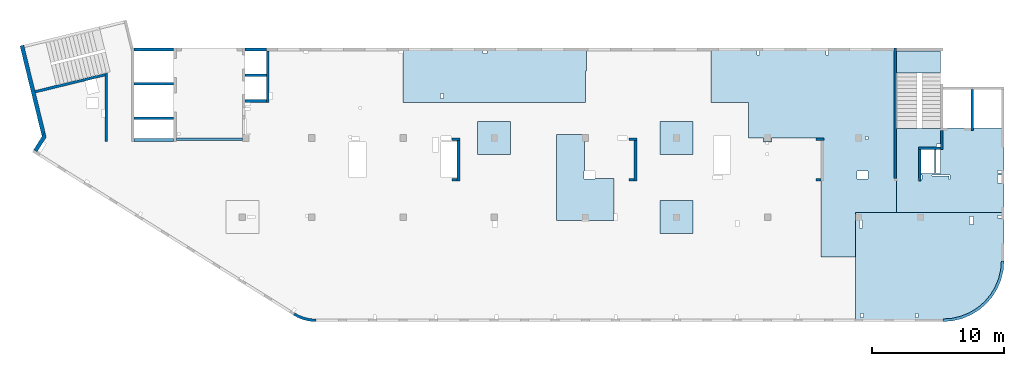
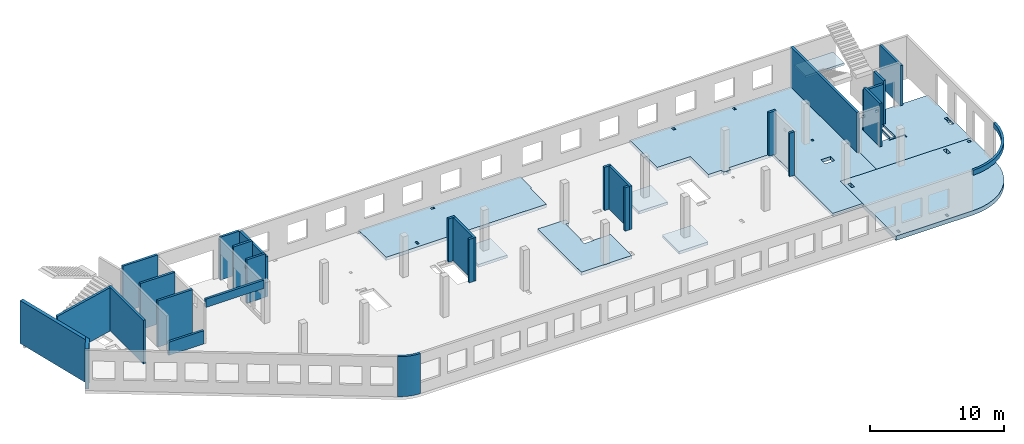
# One storey, part 2 of 6: 28 walls, 9 slabs.
"""IFC4 building model written with IfcOpenShell, lengths in millimetres."""

from ifc_helpers import new_model, entity, si_unit, converted_unit, derived_unit, direction, frame, origin, place, context, subcontext, project, spatial, indexed_curve, outline, extrude, material, type_object, element, save


model = new_model("IFC4")

# Units and contexts
model_context = context("Model", 3, precision=0.01, world=origin(), true_north=direction((6.12303176911189e-17, 1.0)))
plan_context = context("Plan", 3, precision=0.01, world=origin(), true_north=direction((6.12303176911189e-17, 1.0)))
body_context = subcontext(model_context, "Body", "Model", "MODEL_VIEW")
ifc_project = project(units=[si_unit("LENGTHUNIT", "METRE", prefix="MILLI"), si_unit("AREAUNIT", "SQUARE_METRE"), si_unit("VOLUMEUNIT", "CUBIC_METRE"), converted_unit("PLANEANGLEUNIT", "DEGREE", entity("IfcRatioMeasure", 0.0174532925199433), si_unit("PLANEANGLEUNIT", "RADIAN"), dimensions=[0, 0, 0, 0, 0, 0, 0]), si_unit("MASSUNIT", "GRAM", prefix="KILO"), derived_unit("MASSDENSITYUNIT", [(si_unit("MASSUNIT", "GRAM", prefix="KILO"), 1), (si_unit("LENGTHUNIT", "METRE"), -3)]), derived_unit("MOMENTOFINERTIAUNIT", [(si_unit("LENGTHUNIT", "METRE"), 4)]), si_unit("TIMEUNIT", "SECOND"), si_unit("FREQUENCYUNIT", "HERTZ"), si_unit("THERMODYNAMICTEMPERATUREUNIT", "DEGREE_CELSIUS"), derived_unit("THERMALTRANSMITTANCEUNIT", [(si_unit("MASSUNIT", "GRAM", prefix="KILO"), 1), (si_unit("THERMODYNAMICTEMPERATUREUNIT", "KELVIN"), -1), (si_unit("TIMEUNIT", "SECOND"), -3)]), derived_unit("VOLUMETRICFLOWRATEUNIT", [(si_unit("LENGTHUNIT", "METRE"), 3), (si_unit("TIMEUNIT", "SECOND"), -1)]), derived_unit("MASSFLOWRATEUNIT", [(si_unit("MASSUNIT", "GRAM", prefix="KILO"), 1), (si_unit("TIMEUNIT", "SECOND"), -1)]), derived_unit("ROTATIONALFREQUENCYUNIT", [(si_unit("TIMEUNIT", "SECOND"), -1)]), si_unit("ELECTRICCURRENTUNIT", "AMPERE"), si_unit("ELECTRICVOLTAGEUNIT", "VOLT"), si_unit("POWERUNIT", "WATT"), si_unit("FORCEUNIT", "NEWTON", prefix="KILO"), si_unit("ILLUMINANCEUNIT", "LUX"), si_unit("LUMINOUSFLUXUNIT", "LUMEN"), si_unit("LUMINOUSINTENSITYUNIT", "CANDELA"), derived_unit("USERDEFINED", [(si_unit("MASSUNIT", "GRAM", prefix="KILO"), -1), (si_unit("LENGTHUNIT", "METRE"), -2), (si_unit("TIMEUNIT", "SECOND"), 3), (si_unit("LUMINOUSFLUXUNIT", "LUMEN"), 1)]), derived_unit("LINEARVELOCITYUNIT", [(si_unit("LENGTHUNIT", "METRE"), 1), (si_unit("TIMEUNIT", "SECOND"), -1)]), si_unit("PRESSUREUNIT", "PASCAL"), derived_unit("USERDEFINED", [(si_unit("LENGTHUNIT", "METRE"), -2), (si_unit("MASSUNIT", "GRAM", prefix="KILO"), 1), (si_unit("TIMEUNIT", "SECOND"), -2)]), derived_unit("LINEARFORCEUNIT", [(si_unit("MASSUNIT", "GRAM", prefix="KILO"), 1), (si_unit("LENGTHUNIT", "METRE"), 1), (si_unit("TIMEUNIT", "SECOND"), -2), (si_unit("LENGTHUNIT", "METRE"), -1)]), derived_unit("PLANARFORCEUNIT", [(si_unit("MASSUNIT", "GRAM", prefix="KILO"), 1), (si_unit("LENGTHUNIT", "METRE"), 1), (si_unit("TIMEUNIT", "SECOND"), -2), (si_unit("LENGTHUNIT", "METRE"), -2)])], contexts=[model_context, plan_context])

# Site, building, storey
site_placement = place(None, origin())
site = spatial("IfcSite", under=ifc_project, at=site_placement, CompositionType="ELEMENT")
building_placement = place(site_placement, origin())
building = spatial("IfcBuilding", under=site, at=building_placement, CompositionType="ELEMENT")
storey_placement = place(building_placement, frame((0.0, 0.0, 8100.0)))
storey = spatial("IfcBuildingStorey", under=building, at=storey_placement, CompositionType="ELEMENT", Elevation=8100.0)

# Slabs
ifc_material = material()
slab_type_1 = type_object("IfcSlabType", PredefinedType="FLOOR", material=ifc_material)
slab_1_placement = place(storey_placement, origin())
element("IfcSlab", 1, at=slab_1_placement, inside=storey, type_object=slab_type_1, material=ifc_material, PredefinedType="FLOOR", context=body_context, shape_type="SweptSolid", body=[
    extrude(outline(indexed_curve([(-6774.16666666654, -2197.29156649669), (-6774.16666666654, -2497.29156649652), (-6774.16666666654, -6097.29156649676), (-6774.16666666654, -6297.29156649672), (7265.83333333328, -6297.29156649672), (7265.83333333328, -6097.29156649676), (7265.83333333328, -3412.29188617987), (7265.83333333328, -2497.29156649651), (7265.83333333328, -527.291566496528), (7265.83333333329, 6152.70843350346), (4155.83333333329, 6152.70843350346), (4155.83333333329, 9502.70843350343), (1565.83333333329, 9502.70843350343), (1565.83333333328, 502.70843350344), (-2194.16666666669, 502.708433503438), (-2194.16666666669, 802.708433503275), (-2419.16666666676, 802.708433503273), (-2419.16666666676, 792.707391304612), (-2619.16666666675, 792.707391304612), (-2619.16666666675, 802.708433503274), (-2794.16666666671, 802.708433503274), (-2794.16666666671, 502.708433503384), (-3944.16666666658, 502.708433503383), (-3944.16666666658, -2197.29156649669), (-6774.16666666654, -2197.29156649669)], self_intersect=False), holes=[indexed_curve([(5105.83333333324, 402.707391304573), (4905.83333333325, 402.707391304574), (4905.83333333325, 602.707391304598), (5105.83333333324, 602.707391304597), (5105.83333333324, 402.707391304573)], self_intersect=False), indexed_curve([(4290.83333333324, 3017.70739130459), (4290.83333333324, 3617.70739130459), (5120.83333333326, 3617.70739130459), (5120.83333333326, 3017.70739130459), (4290.83333333324, 3017.70739130459)], self_intersect=False), indexed_curve([(2115.83333333324, -5797.29260869539), (2115.83333333324, -6097.29220586319), (1915.83333333322, -6097.29220586319), (1915.83333333322, -5797.29260869539), (2115.83333333324, -5797.29260869539)], self_intersect=False), indexed_curve([(-3094.16666666675, -5797.29260869538), (-3094.16666666675, -6097.29220586318), (-3294.16666666678, -6097.29220586318), (-3294.16666666678, -5797.29260869538), (-3094.16666666675, -5797.29260869538)], self_intersect=False)]), frame((58164.1669352214, 14202.7076598595, -450.0), z_axis=(0.0, 0.0, -1.0), x_axis=(1.0, 0.0, 0.0)), (0.0, 0.0, -1.0), 300.0),
])
slab_type_2 = type_object("IfcSlabType", PredefinedType="FLOOR", material=ifc_material)
slab_2_placement = place(storey_placement, origin())
element("IfcSlab", 2, at=slab_2_placement, inside=storey, type_object=slab_type_2, material=ifc_material, PredefinedType="FLOOR", context=body_context, shape_type="SweptSolid", body=[
    extrude(outline(indexed_curve([(-3285.0, -2417.49999999997), (-3085.00000000002, -2417.49999999997), (1515.00000000001, -2417.49999999998), (1515.00000000001, -2377.50000000001), (4854.99999999999, -2377.50000000002), (4855.0, 4002.49999999997), (-3085.0, 4002.49999999999), (-3284.99999999999, 4002.49999999999), (-3285.0, -2417.49999999997)], self_intersect=False), holes=[indexed_curve([(-3084.99918212893, 1767.49895780109), (-2784.99999999999, 1767.49895780109), (-2784.99999999999, 1167.50000000054), (-3084.99918212893, 1167.50000000054), (-3084.99918212893, 1767.49895780109)], self_intersect=False), indexed_curve([(-3084.99918212893, 1002.49895780108), (-2784.99999999999, 1002.49895780108), (-2784.99999999999, 802.498957801087), (-3084.99918212893, 802.498957801087), (-3084.99918212893, 1002.49895780108)], self_intersect=False), indexed_curve([(1514.99999999996, -1177.50104219891), (1514.99999999996, -977.499999999505), (1815.00000000004, -977.499999999505), (1815.00000000004, -1177.50104219891), (1514.99999999996, -1177.50104219891)], self_intersect=False), indexed_curve([(3005.00000000001, 1487.49895780109), (3005.00000000001, 1147.49895780109), (2925.00000000003, 1147.49895780109), (2925.00000000003, 1487.49895780109), (3005.00000000001, 1487.49895780109)], self_intersect=False), indexed_curve([(3004.99999999993, 1027.49895780109), (3004.99999999993, -777.499999999511), (1965.00000000004, -777.499999999511), (1965.00000000004, 1027.49895780109), (3004.99999999993, 1027.49895780109)], self_intersect=False), indexed_curve([(1515.00000000004, 1027.49895780109), (1845.00000000003, 1027.49895780109), (1845.00000000003, -777.499999999505), (1515.00000000004, -777.499999999505), (1515.00000000004, 1027.49895780109)], self_intersect=False), indexed_curve([(885.000000000007, 1227.49895780108), (2185.00000000002, 1227.49895780108), (2185.00000000002, 1167.49895780109), (805.000000000025, 1167.49895780109), (805.000000000025, 1487.49895780109), (885.000000000007, 1487.49895780109), (885.000000000007, 1227.49895780108)], self_intersect=False)]), frame((70285.0002685547, 12052.499226356, -400.0), z_axis=(0.0, 0.0, 1.0), x_axis=(-1.0, 0.0, 0.0)), (0.0, 0.0, 1.0), 249.999999999999),
])
slab_type_3 = type_object("IfcSlabType", PredefinedType="FLOOR", material=ifc_material)
slab_3_placement = place(storey_placement, origin())
element("IfcSlab", 3, at=slab_3_placement, inside=storey, type_object=slab_type_3, material=ifc_material, PredefinedType="FLOOR", context=body_context, shape_type="SweptSolid", body=[
    extrude(outline(indexed_curve([(-1983.99983184359, -6920.0), (-1784.00047120995, -6920.0), (-1584.00087404217, -6920.0), (1816.00016815662, -6920.00000000001), (2116.00016815641, -6920.00000000001), (2116.00016815645, 6880.0), (1816.00016815666, 6880.0), (-263.999831843444, 6880.0), (-263.999831843444, 6980.0), (-1983.99983184354, 6980.0), (-1983.99983184359, -6920.0)], self_intersect=False), holes=[indexed_curve([(1455.99912595783, -3870.00000000006), (1815.99912595782, -3870.00000000006), (1815.99912595782, -4070.00000000005), (1455.99912595783, -4070.00000000005), (1455.99912595783, -3870.00000000006)], self_intersect=False), indexed_curve([(-1584.00087404217, -570.000000000044), (-1584.00087404217, -870.000000000045), (-1783.9998318435, -870.000000000045), (-1783.9998318435, -570.000000000044), (-1584.00087404217, -570.000000000044)], self_intersect=False)]), frame((34990.0002685547, 18515.9993945127, -450.0), z_axis=(0.0, 0.0, 1.0), x_axis=(0.0, -1.0, 0.0)), (0.0, 0.0, 1.0), 300.0),
])
slab_type_4 = type_object("IfcSlabType", PredefinedType="FLOOR", material=ifc_material)
slab_4_placement = place(storey_placement, origin())
element("IfcSlab", 4, at=slab_4_placement, inside=storey, type_object=slab_type_4, material=ifc_material, PredefinedType="FLOOR", context=body_context, shape_type="SweptSolid", body=[
    extrude(outline(indexed_curve([(-3587.4999999999, -5067.08333333327), (-3287.49999999989, -5067.08333333327), (-512.500000000005, -5067.08333333327), (4462.49999999999, -5067.08333333328), (4662.49999999995, -5067.08333333328), (4662.49999999996, -4667.08333333327), (4662.49999999998, 1582.91666666618), (4605.86636673761, 2302.5152058513), (4437.35997495767, 3004.39484079108), (4161.13001126643, 3671.27296546831), (3783.97817412466, 4286.72882721185), (3315.19119345797, 4835.60786012465), (2766.31216054517, 5304.39484079136), (2150.85629880164, 5681.54667793313), (1483.97817412441, 5957.77664162439), (782.098539184638, 6126.28303340435), (62.4999999994953, 6182.91666666672), (-362.499999999969, 6182.91666666672), (-3587.49999999986, 6182.91666666673), (-3587.49999999986, 5982.91666666674), (-3587.49999999987, 3887.91666666673), (-3587.4999999999, -5067.08333333327)], self_intersect=False), holes=[indexed_curve([(4062.49895780123, -4467.08333333328), (4362.49895780123, -4467.08333333328), (4362.49895780123, -4666.87317969451), (4062.49895780123, -4666.87317969451), (4062.49895780123, -4467.08333333328)], self_intersect=False), indexed_curve([(4062.49895780123, -317.083333333292), (4362.49895780123, -317.083333333292), (4362.49895780123, -517.083333333281), (4062.49895780123, -517.083333333281), (4062.49895780123, -317.083333333292)], self_intersect=False), indexed_curve([(-2677.50104219876, 3887.91666666671), (-2677.50104219876, 3587.9166666667), (-3287.50104219876, 3587.9166666667), (-3287.50104219876, 3887.91666666671), (-2677.50104219876, 3887.91666666671)], self_intersect=False), indexed_curve([(-3362.50104219877, 5982.91584879566), (-3162.50104219878, 5982.91584879566), (-3162.50104219878, 5682.91666666673), (-3362.50104219877, 5682.91666666673), (-3362.50104219877, 5982.91584879566)], self_intersect=False), indexed_curve([(-2427.50104219875, -4767.08333333328), (-2987.49999999956, -4767.08333333328), (-2987.49999999956, -4567.08333333327), (-2987.49999999956, -4517.08333333327), (-2427.50104219875, -4517.08333333327), (-2427.50104219875, -4767.08333333328)], self_intersect=False)]), frame((67387.0836018879, 4462.49922635612, -550.0), z_axis=(0.0, 0.0, 1.0), x_axis=(0.0, -1.0, 0.0)), (0.0, 0.0, 1.0), 400.0),
])
slab_type_5 = type_object("IfcSlabType", PredefinedType="FLOOR", material=ifc_material)
slab_5_placement = place(storey_placement, origin())
element("IfcSlab", 5, at=slab_5_placement, inside=storey, type_object=slab_type_5, material=ifc_material, PredefinedType="FLOOR", context=body_context, shape_type="SweptSolid", body=[
    extrude(outline(indexed_curve([(-3757.49999999989, -2308.33333333336), (2742.5000000001, -2308.33333333336), (2742.5000000001, 116.666666666688), (2242.49999999951, 116.666666666689), (2242.49999999951, -183.333333333312), (-22.4999999999042, -183.333333333309), (-22.4999999999043, -248.333333333355), (-622.499999999904, -248.333333333354), (-622.499999999905, 581.666666666648), (-582.499999999908, 581.666666666648), (-582.49999999991, 2041.66666666668), (-3757.4999999999, 2041.66666666669), (-3757.49999999989, -2308.33333333336)], self_intersect=False)), frame((42003.333601888, 11207.4992263561, -150.0), z_axis=(0.0, 0.0, -1.0), x_axis=(0.0, 1.0, 0.0)), (0.0, 0.0, 1.0), 300.0),
])
slab_type_6 = type_object("IfcSlabType", PredefinedType="FLOOR", material=ifc_material)
slab_6_placement = place(storey_placement, origin())
element("IfcSlab", 6, at=slab_6_placement, inside=storey, type_object=slab_type_6, material=ifc_material, PredefinedType="FLOOR", context=body_context, shape_type="SweptSolid", body=[
    extrude(outline(indexed_curve([(-1250.0, -1249.99999999999), (1250.0, -1249.99999999999), (1250.0, 1250.0), (-1250.0, 1250.0), (-1250.0, -1249.99999999999)], self_intersect=False)), frame((48770.0010131835, 7699.99922635624, -400.0), z_axis=(0.0, 0.0, -1.0), x_axis=(0.0, 1.0, 0.0)), (0.0, 0.0, 1.0), 250.000000000001),
])
slab_type_7 = type_object("IfcSlabType", PredefinedType="FLOOR", material=ifc_material)
slab_7_placement = place(storey_placement, origin())
element("IfcSlab", 7, at=slab_7_placement, inside=storey, type_object=slab_type_7, material=ifc_material, PredefinedType="FLOOR", context=body_context, shape_type="SweptSolid", body=[
    extrude(outline(indexed_curve([(-1250.0, -1250.0), (1250.0, -1250.0), (1250.0, 1249.99999999999), (-1250.0, 1249.99999999999), (-1250.0, -1250.0)], self_intersect=False)), frame((48770.0010131836, 13699.9992263561, -400.0), z_axis=(0.0, 0.0, -1.0), x_axis=(0.0, 1.0, 0.0)), (0.0, 0.0, 1.0), 250.000000000001),
])
slab_type_8 = type_object("IfcSlabType", PredefinedType="FLOOR", material=ifc_material)
slab_8_placement = place(storey_placement, origin())
element("IfcSlab", 8, at=slab_8_placement, inside=storey, type_object=slab_type_8, material=ifc_material, PredefinedType="FLOOR", context=body_context, shape_type="SweptSolid", body=[
    extrude(outline(indexed_curve([(-1250.0, -1249.99999999999), (1250.0, -1249.99999999999), (1250.0, 1250.0), (-1250.0, 1250.0), (-1250.0, -1249.99999999999)], self_intersect=False)), frame((34970.0010131836, 13699.9992263561, -400.0), z_axis=(0.0, 0.0, -1.0), x_axis=(0.0, 1.0, 0.0)), (0.0, 0.0, 1.0), 250.000000000001),
])
slab_type_9 = type_object("IfcSlabType", PredefinedType="FLOOR", material=ifc_material)
slab_9_placement = place(storey_placement, origin())
element("IfcSlab", 9, at=slab_9_placement, inside=storey, type_object=slab_type_9, material=ifc_material, PredefinedType="FLOOR", context=body_context, shape_type="SweptSolid", body=[
    extrude(outline(indexed_curve([(-834.999999999999, -1670.00000000001), (835.000000000001, -1670.00000000001), (835.000000000001, 1670.00000000002), (-834.999999999999, 1670.00000000002), (-834.999999999999, -1670.00000000001)], self_intersect=False)), frame((67100.0002685547, 19464.999226356, 1920.0), z_axis=(0.0, 0.0, -1.0), x_axis=(0.0, 1.0, 0.0)), (0.0, 0.0, 1.0), 200.0),
])

# Walls
wall_type_1 = type_object("IfcWallType", PredefinedType="STANDARD")
wall_1_placement = place(storey_placement, frame((71169.9994506836, 17369.9992263555, -150.0), z_axis=(0.0, 0.0, 1.0), x_axis=(0.0, -1.0, 0.0)))
element("IfcWall", 10, at=wall_1_placement, inside=storey, type_object=wall_type_1, material=ifc_material, PredefinedType="NOTDEFINED", context=body_context, shape_type="SweptSolid", body=[
    extrude(outline(indexed_curve([(3100.0, 100.000000000003), (-2.79449581754433e-13, 100.000000000003), (2.79449581754433e-13, -100.000000000003), (3100.0, -100.000000000003), (3100.0, 100.000000000003)], self_intersect=False)), origin(), (0.0, 0.0, 1.0), 3650.0),
])
wall_2_placement = place(storey_placement, frame((68870.0002685547, 14269.9992263555, -150.0), z_axis=(0.0, 0.0, 1.0), x_axis=(0.0, -1.0, 0.0)))
element("IfcWall", 11, at=wall_2_placement, inside=storey, type_object=wall_type_1, material=ifc_material, PredefinedType="NOTDEFINED", context=body_context, shape_type="SweptSolid", body=[
    extrude(outline(indexed_curve([(1439.99999999999, 100.000000000003), (0.0, 100.000000000003), (0.0, -100.000000000003), (1439.99999999999, -100.000000000003), (1439.99999999999, 100.000000000003)], self_intersect=False)), origin(), (0.0, 0.0, 1.0), 3950.0),
])
wall_3_placement = place(storey_placement, frame((68770.0002685547, 12929.9992263555, -150.0), z_axis=(0.0, 0.0, 1.0), x_axis=(-1.0, 0.0, 0.0)))
element("IfcWall", 12, at=wall_3_placement, inside=storey, type_object=wall_type_1, material=ifc_material, PredefinedType="NOTDEFINED", context=body_context, shape_type="SweptSolid", body=[
    extrude(outline(indexed_curve([(1689.99999999997, 99.9999999999989), (-3.84449868389964e-13, 99.9999999999989), (3.84449868389964e-13, -99.9999999999989), (1689.99999999997, -99.9999999999989), (1689.99999999997, 99.9999999999989)], self_intersect=False)), origin(), (0.0, 0.0, 1.0), 3650.0),
])
wall_4_placement = place(storey_placement, frame((67180.0002685547, 12829.9992263555, -150.0), z_axis=(0.0, 0.0, 1.0), x_axis=(0.0, -1.0, 0.0)))
element("IfcWall", 13, at=wall_4_placement, inside=storey, type_object=wall_type_1, material=ifc_material, PredefinedType="NOTDEFINED", context=body_context, shape_type="SweptSolid", body=[
    extrude(outline(indexed_curve([(2404.99999999995, 100.000000000003), (0.0, 100.000000000003), (0.0, -100.000000000003), (2404.99999999995, -100.000000000003), (2404.99999999995, 100.000000000003)], self_intersect=False)), origin(), (0.0, 0.0, 1.0), 3950.0),
])
wall_5_placement = place(storey_placement, frame((65330.0002685547, 10624.9992263555, -150.0), z_axis=(0.0, 0.0, 1.0), x_axis=(0.0, 1.0, 0.0)))
element("IfcWall", 14, at=wall_5_placement, inside=storey, type_object=wall_type_1, material=ifc_material, PredefinedType="NOTDEFINED", context=body_context, shape_type="SweptSolid", body=[
    extrude(outline(indexed_curve([(9875.00063936713, 100.000000000003), (-1.71685740578866e-13, 100.000000000003), (1.71685740578866e-13, -100.000000000003), (9875.00063936713, -100.000000000004), (9875.00063936713, 100.000000000003)], self_intersect=False)), origin(), (0.0, 0.0, 1.0), 3650.0),
])
wall_6_placement = place(storey_placement, frame((68970.0002685545, -99.9999557734324, 3050.0)))
element("IfcWall", 15, at=wall_6_placement, inside=storey, type_object=wall_type_1, material=ifc_material, PredefinedType="NOTDEFINED", context=body_context, shape_type="SweptSolid", body=[
    extrude(outline(indexed_curve([(4399.99918212903, 4499.99918212888), (4345.82789081698, 3811.68766389508), (4184.64789385715, 3140.32465961517), (3920.42797770043, 2502.44135458057), (3559.67411357824, 1913.74455277455), (3111.26925889869, 1388.72992323025), (2586.25462935438, 940.325068550716), (1997.55782754836, 579.571204428538), (1359.67452251375, 315.351288271842), (688.311518233829, 154.171291312031), (3.46517481375486e-11, 100.0), (0.0, -100.0), (719.598411241839, -43.3663768070014), (1421.47792138871, 125.139985012801), (2088.35592749623, 401.369899590849), (2703.81167981284, 778.521669675706), (3252.69061513597, 1247.30856699292), (3721.47751245321, 1796.18750231603), (4098.6292825381, 2411.64325463263), (4374.85919711618, 3078.52126074015), (4543.365558936, 3780.40077088701), (4599.99918212903, 4499.99918212885), (4399.99918212903, 4499.99918212888)], self_intersect=False)), origin(), (0.0, 0.0, 1.0), 450.000000000002),
])
wall_7_placement = place(storey_placement, frame((19822.3508916672, 371.159404898124, -150.0)))
element("IfcWall", 16, at=wall_7_placement, inside=storey, type_object=wall_type_1, material=ifc_material, PredefinedType="NOTDEFINED", context=body_context, shape_type="SweptSolid", body=[
    extrude(outline(indexed_curve([(1647.48298908956, -371.159642137684), (1479.53495854193, -366.732336838998), (1312.09852486252, -352.905454552832), (1145.69934172072, -329.72240370142), (980.859806418502, -297.255965670987), (818.09741986465, -255.608066320247), (657.923161920899, -204.909455992096), (500.839887220395, -145.319299033065), (347.340746494629, -77.024674109233), (197.907638365059, -0.239986887291593), (53.0096964598414, 84.7937030753815), (-53.0096964598197, -84.7937030753918), (101.553010904459, -175.499182842681), (260.953382356765, -257.405447245706), (424.69099282044, -330.255357933605), (592.251800794088, -393.820208274097), (763.109762144871, -447.900441360165), (936.728481583211, -492.326276503471), (1112.5628966341, -526.958242247616), (1290.06098881835, -551.687614227945), (1468.66551667174, -566.436756503237), (1647.81576516126, -571.159365287708), (1647.48298908956, -371.159642137684)], self_intersect=False)), origin(), (0.0, 0.0, 1.0), 3650.0),
])
wall_8_placement = place(storey_placement, frame((17825.0002685547, 20299.9998657227, -150.0), z_axis=(0.0, 0.0, 1.0), x_axis=(0.0, -1.0, 0.0)))
element("IfcWall", 17, at=wall_8_placement, inside=storey, type_object=wall_type_1, material=ifc_material, PredefinedType="NOTDEFINED", context=body_context, shape_type="SweptSolid", body=[
    extrude(outline(indexed_curve([(3900.00063936684, 99.9999999999989), (-1.66594915657375e-13, 99.9999999999989), (1.66594915657375e-13, -99.9999999999989), (3900.00063936684, -99.9999999999989), (3900.00063936684, 99.9999999999989)], self_intersect=False)), origin(), (0.0, 0.0, 1.0), 3650.0),
])
wall_9_placement = place(storey_placement, frame((17725.0002685547, 16499.9992263558, -150.0), z_axis=(0.0, 0.0, 1.0), x_axis=(-1.0, 0.0, 0.0)))
element("IfcWall", 18, at=wall_9_placement, inside=storey, type_object=wall_type_1, material=ifc_material, PredefinedType="NOTDEFINED", context=body_context, shape_type="SweptSolid", body=[
    extrude(outline(indexed_curve([(1624.99999999999, 99.9999999999982), (-3.56011111002209e-13, 99.9999999999989), (3.56011111002209e-13, -99.9999999999989), (1624.99999999999, -99.9999999999996), (1624.99999999999, 99.9999999999982)], self_intersect=False)), origin(), (0.0, 0.0, 1.0), 3950.0),
])
wall_10_placement = place(storey_placement, frame((5600.00026855469, 13449.9992263559, -150.0), z_axis=(0.0, 0.0, 1.0), x_axis=(0.0, 1.0, 0.0)))
element("IfcWall", 19, at=wall_10_placement, inside=storey, type_object=wall_type_1, material=ifc_material, PredefinedType="NOTDEFINED", context=body_context, shape_type="SweptSolid", body=[
    extrude(outline(indexed_curve([(5191.05764338749, -100.0), (5142.30552742916, 99.9999999999995), (4936.44934265344, 100.0), (-1.37676332088153e-13, 100.0), (1.37676332088153e-13, -100.0), (5191.05764338749, -100.0)], self_intersect=False)), origin(), (0.0, 0.0, 1.0), 3950.0),
])
wall_11_placement = place(storey_placement, frame((220.235605211592, 17202.3781658972, -150.0), z_axis=(0.0, 0.0, 1.0), x_axis=(0.971552058141472, 0.236826092990341, 0.0)))
element("IfcWall", 20, at=wall_11_placement, inside=storey, type_object=wall_type_1, material=ifc_material, PredefinedType="NOTDEFINED", context=body_context, shape_type="SweptSolid", body=[
    extrude(outline(indexed_curve([(5409.98499256816, -100.000000000001), (5458.73710852649, 99.9999999999987), (-1.22668541990834e-13, 100.0), (1.17592602322247e-12, -100.0), (5409.98499256816, -100.000000000001)], self_intersect=False)), origin(), (0.0, 0.0, 1.0), 3950.0),
])
wall_12_placement = place(storey_placement, frame((16100.0002685547, 20399.9998657227, -400.0)))
element("IfcWall", 21, at=wall_12_placement, inside=storey, type_object=wall_type_1, material=ifc_material, PredefinedType="NOTDEFINED", context=body_context, shape_type="SweptSolid", body=[
    extrude(outline(indexed_curve([(1624.99999999999, 99.9999999999989), (-2.66551908750372e-13, 99.9999999999989), (2.66551908750372e-13, -99.9999999999989), (1624.99999999999, -99.9999999999989), (1624.99999999999, 99.9999999999989)], self_intersect=False)), origin(), (0.0, 0.0, 1.0), 3900.0),
])
wall_13_placement = place(storey_placement, frame((16100.0002685547, 18449.9998657227, -400.0)))
element("IfcWall", 22, at=wall_13_placement, inside=storey, type_object=wall_type_1, material=ifc_material, PredefinedType="NOTDEFINED", context=body_context, shape_type="SweptSolid", body=[
    extrude(outline(indexed_curve([(1624.99999999999, 99.9999999999989), (-2.66551908750371e-13, 99.9999999999989), (2.66551908750371e-13, -99.9999999999989), (1624.99999999999, -99.9999999999989), (1624.99999999999, 99.9999999999989)], self_intersect=False)), origin(), (0.0, 0.0, 1.0), 4200.0),
])
wall_14_placement = place(storey_placement, frame((7500.0002685547, 20399.9998657227, -400.0)))
element("IfcWall", 23, at=wall_14_placement, inside=storey, type_object=wall_type_1, material=ifc_material, PredefinedType="NOTDEFINED", context=body_context, shape_type="SweptSolid", body=[
    extrude(outline(indexed_curve([(3200.0, -100.000000000003), (3200.0, 99.9999999999995), (200.0, 99.9999999999995), (200.0, -100.000000000003), (3200.0, -100.000000000003)], self_intersect=False)), origin(), (0.0, 0.0, 1.0), 4200.0),
])
for number, where in (
    (24, (7700.0002685547, 17799.9998657227, -400.0)),
    (25, (7700.00026855469, 15199.9998657227, -400.0)),
):
    element("IfcWall", number, at=place(storey_placement, frame(where)), inside=storey, type_object=wall_type_1, material=ifc_material, PredefinedType="NOTDEFINED", context=body_context, shape_type="SweptSolid", body=[
        extrude(outline(indexed_curve([(3000.0, 99.9999999999989), (-2.88764567812902e-13, 99.9999999999989), (2.88764567812902e-13, -99.9999999999989), (3000.0, -99.9999999999989), (3000.0, 99.9999999999989)], self_intersect=False)), origin(), (0.0, 0.0, 1.0), 4200.0),
    ])
wall_15_placement = place(storey_placement, frame((59330.0002685547, 13599.9992263555, -150.0)))
element("IfcWall", 26, at=wall_15_placement, inside=storey, type_object=wall_type_1, material=ifc_material, PredefinedType="NOTDEFINED", context=body_context, shape_type="SweptSolid", body=[
    extrude(outline(indexed_curve([(599.999999999993, 99.9999999999989), (-3.60955709766131e-13, 99.9999999999989), (3.60955709766131e-13, -99.9999999999989), (599.999999999994, -99.9999999999989), (599.999999999993, 99.9999999999989)], self_intersect=False)), origin(), (0.0, 0.0, 1.0), 3950.0),
])
wall_16_placement = place(storey_placement, frame((59730.0002685547, 10524.9992263555, -150.0), z_axis=(0.0, 0.0, 1.0), x_axis=(-1.0, 0.0, 0.0)))
element("IfcWall", 27, at=wall_16_placement, inside=storey, type_object=wall_type_1, material=ifc_material, PredefinedType="NOTDEFINED", context=body_context, shape_type="SweptSolid", body=[
    extrude(outline(indexed_curve([(399.999999999987, 99.9999999999982), (-3.60955709766136e-13, 99.9999999999989), (3.60955709766136e-13, -99.9999999999989), (399.999999999987, -99.9999999999996), (399.999999999987, 99.9999999999982)], self_intersect=False)), origin(), (0.0, 0.0, 1.0), 3950.0),
])
wall_17_placement = place(storey_placement, frame((45170.0002685547, 13599.9992263556, -150.0)))
element("IfcWall", 28, at=wall_17_placement, inside=storey, type_object=wall_type_1, material=ifc_material, PredefinedType="NOTDEFINED", context=body_context, shape_type="SweptSolid", body=[
    extrude(outline(indexed_curve([(599.999999999993, 99.9999999999989), (-3.60955709766131e-13, 99.9999999999989), (3.60955709766131e-13, -99.9999999999989), (599.999999999994, -99.9999999999989), (599.999999999993, 99.9999999999989)], self_intersect=False)), origin(), (0.0, 0.0, 1.0), 3950.0),
])
wall_18_placement = place(storey_placement, frame((45670.0002685547, 13499.9992263556, -150.0), z_axis=(0.0, 0.0, 1.0), x_axis=(0.0, -1.0, 0.0)))
element("IfcWall", 29, at=wall_18_placement, inside=storey, type_object=wall_type_1, material=ifc_material, PredefinedType="NOTDEFINED", context=body_context, shape_type="SweptSolid", body=[
    extrude(outline(indexed_curve([(3074.99985044015, 100.000000000003), (-2.64517173435081e-13, 100.000000000003), (2.64517173435081e-13, -100.000000000003), (3074.99985044015, -100.000000000004), (3074.99985044015, 100.000000000003)], self_intersect=False)), origin(), (0.0, 0.0, 1.0), 3950.0),
])
wall_19_placement = place(storey_placement, frame((45570.0002685547, 10524.9993759154, -150.0), z_axis=(0.0, 0.0, 1.0), x_axis=(-1.0, 0.0, 0.0)))
element("IfcWall", 30, at=wall_19_placement, inside=storey, type_object=wall_type_1, material=ifc_material, PredefinedType="NOTDEFINED", context=body_context, shape_type="SweptSolid", body=[
    extrude(outline(indexed_curve([(399.999999999995, 99.9999999999982), (-3.60955709766131e-13, 99.9999999999989), (3.60955709766131e-13, -99.9999999999989), (399.999999999996, -99.9999999999996), (399.999999999995, 99.9999999999982)], self_intersect=False)), origin(), (0.0, 0.0, 1.0), 3950.0),
])
wall_20_placement = place(storey_placement, frame((31770.0002685547, 13599.9992263557, -150.0)))
element("IfcWall", 31, at=wall_20_placement, inside=storey, type_object=wall_type_1, material=ifc_material, PredefinedType="NOTDEFINED", context=body_context, shape_type="SweptSolid", body=[
    extrude(outline(indexed_curve([(600.000000000002, 99.9999999999989), (-3.60955709766126e-13, 99.9999999999989), (3.60955709766126e-13, -99.9999999999989), (600.000000000003, -99.9999999999989), (600.000000000002, 99.9999999999989)], self_intersect=False)), origin(), (0.0, 0.0, 1.0), 3950.0),
])
wall_21_placement = place(storey_placement, frame((32270.0002685547, 13499.9992263557, -150.0), z_axis=(0.0, 0.0, 1.0), x_axis=(0.0, -1.0, 0.0)))
element("IfcWall", 32, at=wall_21_placement, inside=storey, type_object=wall_type_1, material=ifc_material, PredefinedType="NOTDEFINED", context=body_context, shape_type="SweptSolid", body=[
    extrude(outline(indexed_curve([(3074.99985044025, 99.9999999999987), (-1.32258586717531e-13, 99.9999999999989), (1.32258586717531e-13, -99.9999999999989), (3074.99985044025, -99.9999999999992), (3074.99985044025, 99.9999999999987)], self_intersect=False)), origin(), (0.0, 0.0, 1.0), 3950.0),
])
wall_22_placement = place(storey_placement, frame((32170.0002685547, 10524.9993759155, -150.0), z_axis=(0.0, 0.0, 1.0), x_axis=(-1.0, 0.0, 0.0)))
element("IfcWall", 33, at=wall_22_placement, inside=storey, type_object=wall_type_1, material=ifc_material, PredefinedType="NOTDEFINED", context=body_context, shape_type="SweptSolid", body=[
    extrude(outline(indexed_curve([(399.999999999995, 99.9999999999982), (-3.60955709766131e-13, 99.9999999999989), (3.60955709766131e-13, -99.9999999999989), (399.999999999996, -99.9999999999996), (399.999999999995, 99.9999999999982)], self_intersect=False)), origin(), (0.0, 0.0, 1.0), 3950.0),
])
wall_23_placement = place(storey_placement, frame((10900.0002685547, 13599.9992263559, 3050.0)))
element("IfcWall", 34, at=wall_23_placement, inside=storey, type_object=wall_type_1, material=ifc_material, PredefinedType="NOTDEFINED", context=body_context, shape_type="SweptSolid", body=[
    extrude(outline(indexed_curve([(4999.99925537109, 99.9999999999989), (-3.03202841358267e-13, 99.9999999999989), (3.03202841358267e-13, -99.9999999999989), (4999.99925537109, -99.9999999999989), (4999.99925537109, 99.9999999999989)], self_intersect=False)), origin(), (0.0, 0.0, 1.0), 749.999999999998),
])
wall_24_placement = place(storey_placement, frame((7700.00026855469, 13549.9992263559, -150.0)))
element("IfcWall", 35, at=wall_24_placement, inside=storey, type_object=wall_type_1, material=ifc_material, PredefinedType="NOTDEFINED", context=body_context, shape_type="SweptSolid", body=[
    extrude(outline(indexed_curve([(3000.0, 99.9999999999989), (-2.88764567812902e-13, 99.9999999999989), (2.88764567812902e-13, -99.9999999999989), (3000.0, -99.9999999999989), (3000.0, 99.9999999999989)], self_intersect=False)), origin(), (0.0, 0.0, 1.0), 1200.0),
])
wall_type_2 = type_object("IfcWallType", PredefinedType="STANDARD")
wall_25_placement = place(storey_placement, frame((233.05018952286, 12729.5913450927, -150.0), z_axis=(0.0, 0.0, 1.0), x_axis=(0.529911826412024, 0.848052743777575, 0.0)))
element("IfcWall", 36, at=wall_25_placement, inside=storey, type_object=wall_type_2, material=ifc_material, PredefinedType="NOTDEFINED", context=body_context, shape_type="SweptSolid", body=[
    extrude(outline(indexed_curve([(1316.31557757947, -150.0), (1609.08571844498, 150.0), (1189.90275674163, 150.000000000001), (2.08113526412035e-12, 150.0), (9.05209240897875e-13, -150.0), (100.258465181471, -150.0), (900.258465181472, -150.0), (1316.31557757947, -150.0)], self_intersect=False)), origin(), (0.0, 0.0, 1.0), 3650.0),
])
wall_26_placement = place(storey_placement, frame((-787.544181994463, 20703.3037435836, -400.0), z_axis=(0.0, 0.0, 1.0), x_axis=(0.236826092990339, -0.971552058141473, 0.0)))
element("IfcWall", 37, at=wall_26_placement, inside=storey, type_object=wall_type_2, material=ifc_material, PredefinedType="NOTDEFINED", context=body_context, shape_type="SweptSolid", body=[
    extrude(outline(indexed_curve([(7050.16407046696, -150.0), (6757.39392960146, 150.0), (-2.19957385638736e-13, 150.0), (1.86117787848161e-13, -150.0), (7050.16407046696, -150.0)], self_intersect=False)), origin(), (0.0, 0.0, 1.0), 3900.0),
])

save(model, "model.ifc")
